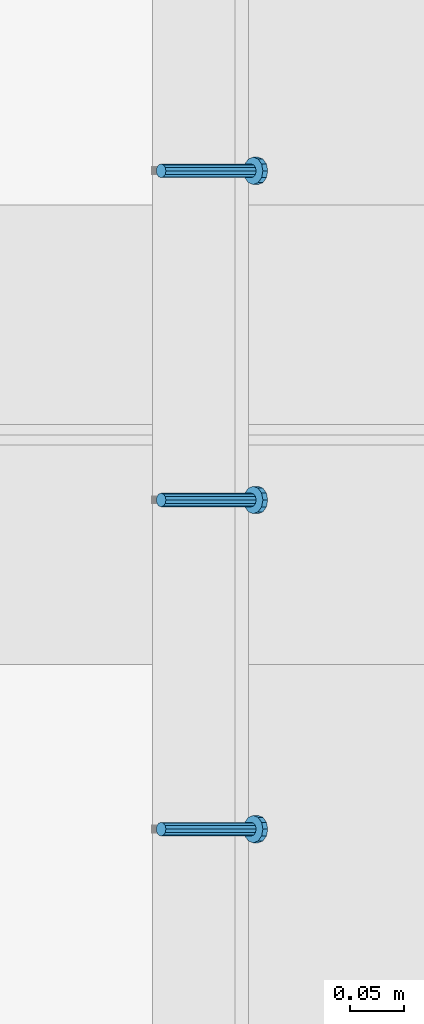
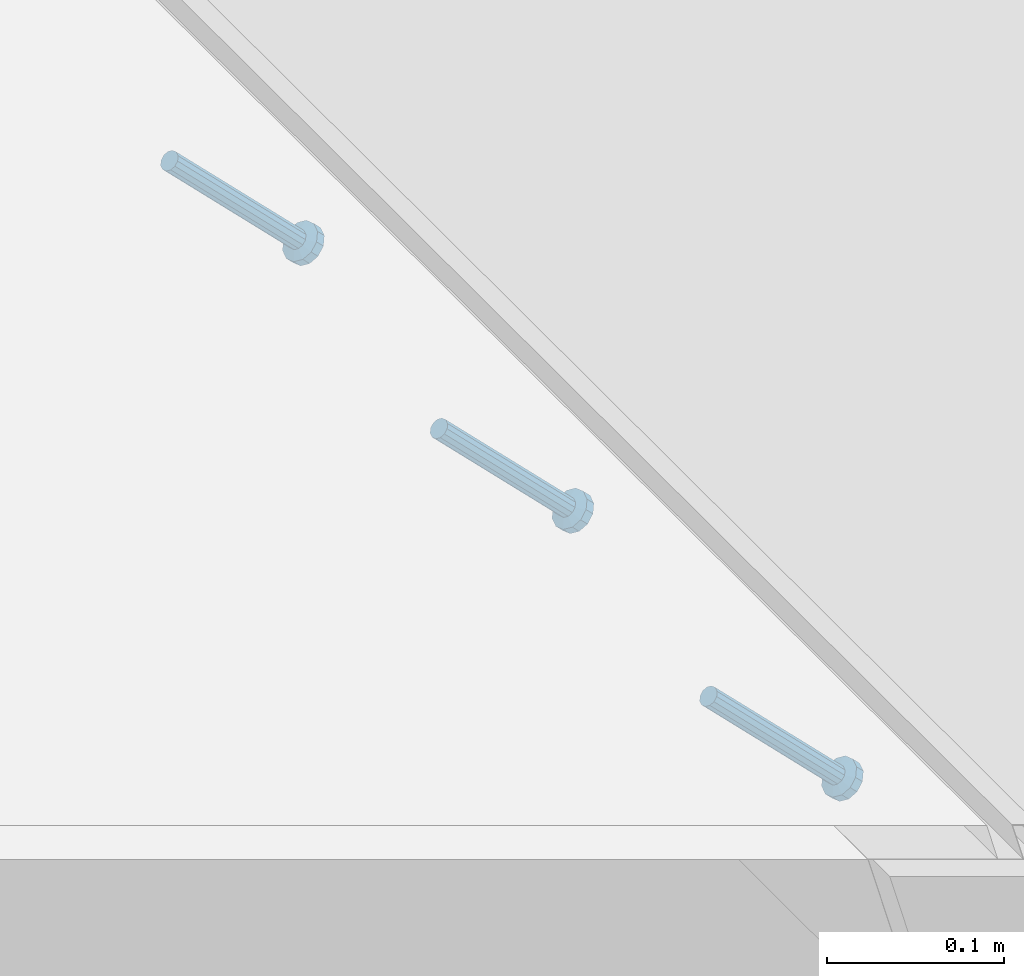
# One storey, part 2376 of 3843: 3 members, 1 element without a shape of its own.
"""IFC2X3 building model written with IfcOpenShell, lengths in millimetres."""

import ifcopenshell
import ifcopenshell.guid

model = None  # the IFC model being written
_history = None  # IfcOwnerHistory: only IFC2X3 demands one
_inside = {}  # id of a spatial element -> (the spatial element, [elements in it])
_under = {}  # id of a project, library or spatial element -> (it, [spatial elements below it])
_declared = {}  # id of a project -> (the project, [libraries it declares])
_typed = {}  # id of a type object -> (the type object, [elements of that type])
_made_of = {}  # id of a material, layer set ... -> (it, [elements and type objects made of it])


def new_model(schema):
    """Start an empty IFC model of exactly this schema.

    Asked for "IFC4X3", IfcOpenShell would pick the latest addendum, in which some entities
    have other attributes; the version numbers below select the first issue.
    IFC2X3 requires an IfcOwnerHistory on every rooted entity: one is made here for all.
    """
    global model, _history
    if schema == "IFC4X3":
        model = ifcopenshell.file(schema_version=(4, 3, 0, 0))
    else:
        model = ifcopenshell.file(schema=schema)
    _inside.clear()
    _under.clear()
    _declared.clear()
    _typed.clear()
    _made_of.clear()
    _history = None
    if model.schema == "IFC2X3":
        org = make("IfcOrganization", Name="unknown")
        user = make(
            "IfcPersonAndOrganization",
            ThePerson=make("IfcPerson", FamilyName="unknown"),
            TheOrganization=org,
        )
        app = make(
            "IfcApplication",
            ApplicationDeveloper=org,
            Version="unknown",
            ApplicationFullName="unknown",
            ApplicationIdentifier="unknown",
        )
        _history = make(
            "IfcOwnerHistory",
            OwningUser=user,
            OwningApplication=app,
            ChangeAction="ADDED",
            CreationDate=0,
        )
    return model


def make(cls, **values):
    """One entity of the class cls with the attributes given. An attribute that is None is left unset."""
    return model.create_entity(
        cls, **{name: value for name, value in values.items() if value is not None}
    )


def rooted(cls, **values):
    """An entity with a GlobalId (a new one), such as an element, a storey or a relation."""
    return make(cls, GlobalId=ifcopenshell.guid.new(), OwnerHistory=_history, **values)


def si_unit(unit_type, name, prefix=None):
    """IfcSIUnit, for example si_unit("LENGTHUNIT", "METRE", prefix="MILLI")."""
    return make("IfcSIUnit", UnitType=unit_type, Prefix=prefix, Name=name)


def assignment(units):
    """IfcUnitAssignment: the units of a project."""
    return None if units is None else make("IfcUnitAssignment", Units=units)


def point(xyz):
    """IfcCartesianPoint."""
    return None if xyz is None else make("IfcCartesianPoint", Coordinates=xyz)


def direction(xyz):
    """IfcDirection."""
    return None if xyz is None else make("IfcDirection", DirectionRatios=xyz)


def frame(location, z_axis=None, x_axis=None):
    """IfcAxis2Placement3D, a coordinate frame: its origin and axes. An axis left out is left unset."""
    return make(
        "IfcAxis2Placement3D",
        Location=point(location),
        Axis=direction(z_axis),
        RefDirection=direction(x_axis),
    )


def origin_with_axes():
    """The frame at (0, 0, 0) with the z axis (0, 0, 1) and the x axis (1, 0, 0) written out."""
    return frame((0.0, 0.0, 0.0), z_axis=(0.0, 0.0, 1.0), x_axis=(1.0, 0.0, 0.0))


def place(relative_to, where):
    """IfcLocalPlacement: puts the frame where relative to a parent placement (None: the world)."""
    return make(
        "IfcLocalPlacement", PlacementRelTo=relative_to, RelativePlacement=where
    )


def context(
    kind, dimensions, precision=None, world=None, true_north=None, identifier=None
):
    """IfcGeometricRepresentationContext, for example the 3D "Model" context."""
    return make(
        "IfcGeometricRepresentationContext",
        ContextIdentifier=identifier,
        ContextType=kind,
        CoordinateSpaceDimension=dimensions,
        Precision=precision,
        WorldCoordinateSystem=world,
        TrueNorth=true_north,
    )


def subcontext(parent, identifier, kind, view, scale=None):
    """IfcGeometricRepresentationSubContext, for example "Body" below "Model"."""
    return make(
        "IfcGeometricRepresentationSubContext",
        ContextIdentifier=identifier,
        ContextType=kind,
        ParentContext=parent,
        TargetScale=scale,
        TargetView=view,
    )


def project(units=None, contexts=None):
    """IfcProject with its units and contexts."""
    return rooted(
        "IfcProject",
        Name="project",
        RepresentationContexts=contexts,
        UnitsInContext=assignment(units),
    )


def spatial(cls, under=None, at=None, **own):
    """A site, building, storey or space (cls), placed at a placement, below another one or the project."""
    s = rooted(cls, ObjectPlacement=at, **own)
    if under is not None:
        _under.setdefault(under.id(), (under, []))[1].append(s)
    return s


def faces_of(points, faces, orient=None, outer=None):
    """IfcFace entities. A face is a list of loops; a loop is a list of indices into points, from 0.

    orient and outer hold one flag for each loop. By default every Orientation is true, the
    first loop of a face is its IfcFaceOuterBound and the others are IfcFaceBound.
    """
    made = []
    for i, loops in enumerate(faces):
        bounds = []
        for j, loop in enumerate(loops):
            is_outer = j == 0 if outer is None else outer[i][j]
            bounds.append(
                make(
                    "IfcFaceOuterBound" if is_outer else "IfcFaceBound",
                    Bound=make("IfcPolyLoop", Polygon=[points[k] for k in loop]),
                    Orientation=True if orient is None else orient[i][j],
                )
            )
        made.append(make("IfcFace", Bounds=bounds))
    return made


def faceted_brep(points, faces, orient=None, outer=None, voids=None):
    """IfcFacetedBrep: a solid bounded by flat faces; with voids (closed shells), ...WithVoids."""
    shared = [point(p) for p in points]
    hull = make("IfcClosedShell", CfsFaces=faces_of(shared, faces, orient, outer))
    if voids is None:
        return make("IfcFacetedBrep", Outer=hull)
    return make(
        "IfcFacetedBrepWithVoids",
        Outer=hull,
        Voids=[
            make(cls, CfsFaces=faces_of(shared, fs, o, b)) for cls, fs, o, b in voids
        ],
    )


def shape(context_of_items, identifier, shape_type, items):
    """IfcShapeRepresentation: the items that make up one representation, for example the "Body"."""
    return make(
        "IfcShapeRepresentation",
        ContextOfItems=context_of_items,
        RepresentationIdentifier=identifier,
        RepresentationType=shape_type,
        Items=items,
    )


def material(Name=None, Category=None):
    """IfcMaterial."""
    return make("IfcMaterial", Name=Name, Category=Category)


def made_of(thing, what):
    """Note that an element or type object is made of a material, layer set ...; save() writes the relation."""
    if what is not None:
        _made_of.setdefault(what.id(), (what, []))[1].append(thing)
    return thing


def type_object(cls, material=None, **own):
    """A type object (cls), such as IfcWallType, which elements share."""
    return made_of(rooted(cls, **own), material)


def element(
    cls,
    number,
    at=None,
    inside=None,
    cuts=None,
    type_object=None,
    material=None,
    context=None,
    identifier="Body",
    shape_type=None,
    held_by="IfcProductDefinitionShape",
    body=None,
    shapes=None,
    **own,
):
    """One element of the class cls, such as IfcWall. Its Tag is "e" and its number.

    at: its placement. inside: the storey or other place that contains it. cuts: it is an
    opening in that element (IfcRelVoidsElement). A single representation is given by context,
    identifier, shape_type and body (its items); several are given by shapes. held_by: the class
    of the entity that holds the representations. save() writes the other relations.
    """
    e = rooted(cls, Tag="e%d" % number, ObjectPlacement=at, **own)
    if body is not None:
        shapes = [shape(context, identifier, shape_type, body)]
    if shapes is not None:
        e.Representation = make(held_by, Representations=shapes)
    if inside is not None:
        _inside.setdefault(inside.id(), (inside, []))[1].append(e)
    if cuts is not None:
        rooted(
            "IfcRelVoidsElement", RelatingBuildingElement=cuts, RelatedOpeningElement=e
        )
    if type_object is not None:
        _typed.setdefault(type_object.id(), (type_object, []))[1].append(e)
    return made_of(e, material)


def aggregate(whole, parts):
    """IfcRelAggregates: a whole, such as a stair, and the parts it consists of."""
    return rooted("IfcRelAggregates", RelatingObject=whole, RelatedObjects=parts)


def save(model, path):
    """Write the relations noted so far, then the file.

    IfcRelAggregates (storeys below a building ...), IfcRelContainedInSpatialStructure (elements
    in a storey), IfcRelDefinesByType, IfcRelAssociatesMaterial and IfcRelDeclares: one each for
    every whole, place, type object, material and project.
    """
    for whole, parts in _under.values():
        aggregate(whole, parts)
    for where, things in _inside.values():
        rooted(
            "IfcRelContainedInSpatialStructure",
            RelatedElements=things,
            RelatingStructure=where,
        )
    for kind, things in _typed.values():
        rooted("IfcRelDefinesByType", RelatedObjects=things, RelatingType=kind)
    for what, things in _made_of.values():
        rooted("IfcRelAssociatesMaterial", RelatedObjects=things, RelatingMaterial=what)
    for by, libraries in _declared.values():
        rooted("IfcRelDeclares", RelatingContext=by, RelatedDefinitions=libraries)
    model.write(path)


model = new_model("IFC2X3")

# Units and contexts
model_context = context("Model", 3, precision=1e-05, world=origin_with_axes())
body_context = subcontext(model_context, "Body", "Model", "MODEL_VIEW")
ifc_project = project(units=[si_unit("LENGTHUNIT", "METRE", prefix="MILLI"), si_unit("AREAUNIT", "SQUARE_METRE"), si_unit("VOLUMEUNIT", "CUBIC_METRE"), si_unit("MASSUNIT", "GRAM", prefix="KILO"), si_unit("TIMEUNIT", "SECOND"), si_unit("PLANEANGLEUNIT", "RADIAN"), si_unit("SOLIDANGLEUNIT", "STERADIAN"), si_unit("THERMODYNAMICTEMPERATUREUNIT", "DEGREE_CELSIUS"), si_unit("LUMINOUSINTENSITYUNIT", "LUMEN")], contexts=[model_context])

# Site, building, storey
site_placement = place(None, origin_with_axes())
site = spatial("IfcSite", under=ifc_project, at=site_placement, CompositionType="ELEMENT")
building_placement = place(site_placement, origin_with_axes())
building = spatial("IfcBuilding", under=site, at=building_placement, Name="Undefined", CompositionType="ELEMENT")
storey_placement = place(building_placement, origin_with_axes())
storey = spatial("IfcBuildingStorey", under=building, at=storey_placement, Name="Undefined", CompositionType="ELEMENT", Elevation=0.0)

# Assembly, members
assembly_placement = place(storey_placement, origin_with_axes())
assembly = element("IfcElementAssembly", 1, at=assembly_placement, inside=storey, Name="EMBED_ANGLE", AssemblyPlace="NOTDEFINED", PredefinedType="RIGID_FRAME")
ifc_material = material(Name="STEEL/A108")
member_type = type_object("IfcMemberType", PredefinedType="NOTDEFINED")
member_1_placement = place(assembly_placement, frame((44851.3834999999, 66906.775189209, 30456.1875), z_axis=(0.0, 1.0, 0.0), x_axis=(0.707106781186548, 0.0, -0.707106781186548)))
member_1 = element("IfcMember", 2, at=member_1_placement, type_object=member_type, material=ifc_material, Name="HEADED STUD ANCHOR", context=body_context, shape_type="Brep", body=[
    faceted_brep([(7.27595761418343e-12, -3.18000006675175, 5.5), (0.0, -5.49999999998363, 3.1800000667572), (118.110000000976, -5.49999999999091, 3.1800000667572), (118.110000000983, -3.18000006675175, 5.5), (0.0, -6.3499999046162, 0.0), (118.110000000968, -6.34999990461256, 0.0), (0.0, -5.49999999998363, -3.1800000667572), (118.110000000976, -5.49999999999091, -3.1800000667572), (7.27595761418343e-12, -3.18000006675175, -5.5), (118.110000000983, -3.18000006675175, -5.5), (7.27595761418343e-12, -1.81898940354586e-12, -6.34999990463257), (118.110000000968, -1.81898940354586e-12, -6.34999990463257), (0.0, 3.18000006675175, -5.5), (118.110000000968, 3.18000006674811, -5.5), (7.27595761418343e-12, 5.49999999998363, -3.1800000667572), (118.110000000983, 5.49999999998363, -3.1800000667572), (7.27595761418343e-12, 6.3499999046162, 0.0), (118.110000000976, 6.34999990461256, 0.0), (7.27595761418343e-12, 5.49999999998363, 3.1800000667572), (118.110000000983, 5.49999999998363, 3.1800000667572), (0.0, 3.18000006675175, 5.5), (118.110000000968, 3.18000006674811, 5.5), (7.27595761418343e-12, -1.81898940354586e-12, 6.34999990463257), (118.110000000968, -1.81898940354586e-12, 6.34999990463257), (120.650000000991, -10.9899997710909, 6.34999990463257), (120.650000000998, -6.34000015257152, 10.9899997711182), (120.650000000991, -12.6999998092379, 0.0), (120.650000000991, -10.9899997710909, -6.34999990463257), (120.650000000998, -6.34000015257152, -10.9899997711182), (120.650000000991, -1.81898940354586e-12, -12.6899995803833), (120.650000000991, 6.34000015257152, -10.9899997711182), (120.650000000998, 10.9899997710909, -6.34999990463257), (120.650000000991, 12.6999998092342, 0.0), (120.650000000998, 10.9899997710909, 6.34999990463257), (120.650000000991, 6.34000015257152, 10.9899997711182), (120.650000000991, -1.81898940354586e-12, 12.6899995803833), (127.000000001048, -10.9899997710945, 6.34999990463257), (127.000000001048, -6.34000015257152, 10.9899997711182), (127.000000001048, -12.6999998092342, 0.0), (127.000000001048, -10.9899997710945, -6.34999990463257), (127.000000001048, -6.34000015257152, -10.9899997711182), (127.000000001048, 1.81898940354586e-12, -12.6899995803833), (127.000000001048, 6.34000015256788, -10.9899997711182), (127.000000001048, 10.9899997710909, -6.34999990463257), (127.000000001048, 12.6999998092379, 0.0), (127.000000001048, 10.9899997710909, 6.34999990463257), (127.000000001048, 6.34000015256788, 10.9899997711182), (127.000000001048, 1.81898940354586e-12, 12.6899995803833)], [[[0, 1, 2, 3]], [[1, 4, 5, 2]], [[4, 6, 7, 5]], [[6, 8, 9, 7]], [[8, 10, 11, 9]], [[10, 12, 13, 11]], [[12, 14, 15, 13]], [[14, 16, 17, 15]], [[16, 18, 19, 17]], [[18, 20, 21, 19]], [[20, 22, 23, 21]], [[22, 0, 3, 23]], [[22, 20, 18, 16, 14, 12, 10, 8, 6, 4, 1, 0]], [[3, 2, 24, 25]], [[2, 5, 26, 24]], [[5, 7, 27, 26]], [[7, 9, 28, 27]], [[9, 11, 29, 28]], [[11, 13, 30, 29]], [[13, 15, 31, 30]], [[15, 17, 32, 31]], [[17, 19, 33, 32]], [[19, 21, 34, 33]], [[21, 23, 35, 34]], [[23, 3, 25, 35]], [[25, 24, 36, 37]], [[24, 26, 38, 36]], [[26, 27, 39, 38]], [[27, 28, 40, 39]], [[28, 29, 41, 40]], [[29, 30, 42, 41]], [[30, 31, 43, 42]], [[31, 32, 44, 43]], [[32, 33, 45, 44]], [[33, 34, 46, 45]], [[34, 35, 47, 46]], [[35, 25, 37, 47]], [[38, 39, 40, 41, 42, 43, 44, 45, 46, 47, 37, 36]]]),
])
member_2_placement = place(assembly_placement, frame((44851.3834999999, 67211.575189209, 30456.1875), z_axis=(0.0, 1.0, 0.0), x_axis=(0.707106781186548, 0.0, -0.707106781186548)))
member_2 = element("IfcMember", 3, at=member_2_placement, type_object=member_type, material=ifc_material, Name="HEADED STUD ANCHOR", context=body_context, shape_type="Brep", body=[
    faceted_brep([(7.27595761418343e-12, -3.18000006675175, 5.5), (0.0, -5.49999999998363, 3.1800000667572), (118.110000000976, -5.49999999999091, 3.1800000667572), (118.110000000983, -3.18000006675175, 5.5), (0.0, -6.3499999046162, 0.0), (118.110000000968, -6.34999990461256, 0.0), (0.0, -5.49999999998363, -3.1800000667572), (118.110000000976, -5.49999999999091, -3.1800000667572), (7.27595761418343e-12, -3.18000006675175, -5.5), (118.110000000983, -3.18000006675175, -5.5), (7.27595761418343e-12, -1.81898940354586e-12, -6.34999990463257), (118.110000000968, -1.81898940354586e-12, -6.34999990463257), (0.0, 3.18000006675175, -5.5), (118.110000000968, 3.18000006674811, -5.5), (7.27595761418343e-12, 5.49999999998363, -3.1800000667572), (118.110000000983, 5.49999999998363, -3.1800000667572), (7.27595761418343e-12, 6.3499999046162, 0.0), (118.110000000976, 6.34999990461256, 0.0), (7.27595761418343e-12, 5.49999999998363, 3.1800000667572), (118.110000000983, 5.49999999998363, 3.1800000667572), (0.0, 3.18000006675175, 5.5), (118.110000000968, 3.18000006674811, 5.5), (7.27595761418343e-12, -1.81898940354586e-12, 6.34999990463257), (118.110000000968, -1.81898940354586e-12, 6.34999990463257), (120.650000000991, -10.9899997710909, 6.34999990463257), (120.650000000998, -6.34000015257152, 10.9899997711182), (120.650000000991, -12.6999998092379, 0.0), (120.650000000991, -10.9899997710909, -6.34999990463257), (120.650000000998, -6.34000015257152, -10.9899997711182), (120.650000000991, -1.81898940354586e-12, -12.6899995803833), (120.650000000991, 6.34000015257152, -10.9899997711182), (120.650000000998, 10.9899997710909, -6.34999990463257), (120.650000000991, 12.6999998092342, 0.0), (120.650000000998, 10.9899997710909, 6.34999990463257), (120.650000000991, 6.34000015257152, 10.9899997711182), (120.650000000991, -1.81898940354586e-12, 12.6899995803833), (127.000000001048, -10.9899997710945, 6.34999990463257), (127.000000001048, -6.34000015257152, 10.9899997711182), (127.000000001048, -12.6999998092342, 0.0), (127.000000001048, -10.9899997710945, -6.34999990463257), (127.000000001048, -6.34000015257152, -10.9899997711182), (127.000000001048, 1.81898940354586e-12, -12.6899995803833), (127.000000001048, 6.34000015256788, -10.9899997711182), (127.000000001048, 10.9899997710909, -6.34999990463257), (127.000000001048, 12.6999998092379, 0.0), (127.000000001048, 10.9899997710909, 6.34999990463257), (127.000000001048, 6.34000015256788, 10.9899997711182), (127.000000001048, 1.81898940354586e-12, 12.6899995803833)], [[[0, 1, 2, 3]], [[1, 4, 5, 2]], [[4, 6, 7, 5]], [[6, 8, 9, 7]], [[8, 10, 11, 9]], [[10, 12, 13, 11]], [[12, 14, 15, 13]], [[14, 16, 17, 15]], [[16, 18, 19, 17]], [[18, 20, 21, 19]], [[20, 22, 23, 21]], [[22, 0, 3, 23]], [[22, 20, 18, 16, 14, 12, 10, 8, 6, 4, 1, 0]], [[3, 2, 24, 25]], [[2, 5, 26, 24]], [[5, 7, 27, 26]], [[7, 9, 28, 27]], [[9, 11, 29, 28]], [[11, 13, 30, 29]], [[13, 15, 31, 30]], [[15, 17, 32, 31]], [[17, 19, 33, 32]], [[19, 21, 34, 33]], [[21, 23, 35, 34]], [[23, 3, 25, 35]], [[25, 24, 36, 37]], [[24, 26, 38, 36]], [[26, 27, 39, 38]], [[27, 28, 40, 39]], [[28, 29, 41, 40]], [[29, 30, 42, 41]], [[30, 31, 43, 42]], [[31, 32, 44, 43]], [[32, 33, 45, 44]], [[33, 34, 46, 45]], [[34, 35, 47, 46]], [[35, 25, 37, 47]], [[38, 39, 40, 41, 42, 43, 44, 45, 46, 47, 37, 36]]]),
])
member_3_placement = place(assembly_placement, frame((44851.3834999999, 67516.375189209, 30456.1875), z_axis=(0.0, 1.0, 0.0), x_axis=(0.707106781186548, 0.0, -0.707106781186548)))
member_3 = element("IfcMember", 4, at=member_3_placement, type_object=member_type, material=ifc_material, Name="HEADED STUD ANCHOR", context=body_context, shape_type="Brep", body=[
    faceted_brep([(7.27595761418343e-12, -3.18000006675175, 5.5), (0.0, -5.49999999998363, 3.1800000667572), (118.110000000976, -5.49999999999091, 3.1800000667572), (118.110000000983, -3.18000006675175, 5.5), (0.0, -6.3499999046162, 0.0), (118.110000000968, -6.34999990461256, 0.0), (0.0, -5.49999999998363, -3.1800000667572), (118.110000000976, -5.49999999999091, -3.1800000667572), (7.27595761418343e-12, -3.18000006675175, -5.5), (118.110000000983, -3.18000006675175, -5.5), (7.27595761418343e-12, -1.81898940354586e-12, -6.34999990463257), (118.110000000968, -1.81898940354586e-12, -6.34999990463257), (0.0, 3.18000006675175, -5.5), (118.110000000968, 3.18000006674811, -5.5), (7.27595761418343e-12, 5.49999999998363, -3.1800000667572), (118.110000000983, 5.49999999998363, -3.1800000667572), (7.27595761418343e-12, 6.3499999046162, 0.0), (118.110000000976, 6.34999990461256, 0.0), (7.27595761418343e-12, 5.49999999998363, 3.1800000667572), (118.110000000983, 5.49999999998363, 3.1800000667572), (0.0, 3.18000006675175, 5.5), (118.110000000968, 3.18000006674811, 5.5), (7.27595761418343e-12, -1.81898940354586e-12, 6.34999990463257), (118.110000000968, -1.81898940354586e-12, 6.34999990463257), (120.650000000991, -10.9899997710909, 6.34999990463257), (120.650000000998, -6.34000015257152, 10.9899997711182), (120.650000000991, -12.6999998092379, 0.0), (120.650000000991, -10.9899997710909, -6.34999990463257), (120.650000000998, -6.34000015257152, -10.9899997711182), (120.650000000991, -1.81898940354586e-12, -12.6899995803833), (120.650000000991, 6.34000015257152, -10.9899997711182), (120.650000000998, 10.9899997710909, -6.34999990463257), (120.650000000991, 12.6999998092342, 0.0), (120.650000000998, 10.9899997710909, 6.34999990463257), (120.650000000991, 6.34000015257152, 10.9899997711182), (120.650000000991, -1.81898940354586e-12, 12.6899995803833), (127.000000001048, -10.9899997710945, 6.34999990463257), (127.000000001048, -6.34000015257152, 10.9899997711182), (127.000000001048, -12.6999998092342, 0.0), (127.000000001048, -10.9899997710945, -6.34999990463257), (127.000000001048, -6.34000015257152, -10.9899997711182), (127.000000001048, 1.81898940354586e-12, -12.6899995803833), (127.000000001048, 6.34000015256788, -10.9899997711182), (127.000000001048, 10.9899997710909, -6.34999990463257), (127.000000001048, 12.6999998092379, 0.0), (127.000000001048, 10.9899997710909, 6.34999990463257), (127.000000001048, 6.34000015256788, 10.9899997711182), (127.000000001048, 1.81898940354586e-12, 12.6899995803833)], [[[0, 1, 2, 3]], [[1, 4, 5, 2]], [[4, 6, 7, 5]], [[6, 8, 9, 7]], [[8, 10, 11, 9]], [[10, 12, 13, 11]], [[12, 14, 15, 13]], [[14, 16, 17, 15]], [[16, 18, 19, 17]], [[18, 20, 21, 19]], [[20, 22, 23, 21]], [[22, 0, 3, 23]], [[22, 20, 18, 16, 14, 12, 10, 8, 6, 4, 1, 0]], [[3, 2, 24, 25]], [[2, 5, 26, 24]], [[5, 7, 27, 26]], [[7, 9, 28, 27]], [[9, 11, 29, 28]], [[11, 13, 30, 29]], [[13, 15, 31, 30]], [[15, 17, 32, 31]], [[17, 19, 33, 32]], [[19, 21, 34, 33]], [[21, 23, 35, 34]], [[23, 3, 25, 35]], [[25, 24, 36, 37]], [[24, 26, 38, 36]], [[26, 27, 39, 38]], [[27, 28, 40, 39]], [[28, 29, 41, 40]], [[29, 30, 42, 41]], [[30, 31, 43, 42]], [[31, 32, 44, 43]], [[32, 33, 45, 44]], [[33, 34, 46, 45]], [[34, 35, 47, 46]], [[35, 25, 37, 47]], [[38, 39, 40, 41, 42, 43, 44, 45, 46, 47, 37, 36]]]),
])
aggregate(assembly, [member_1, member_2, member_3])

save(model, "model.ifc")
